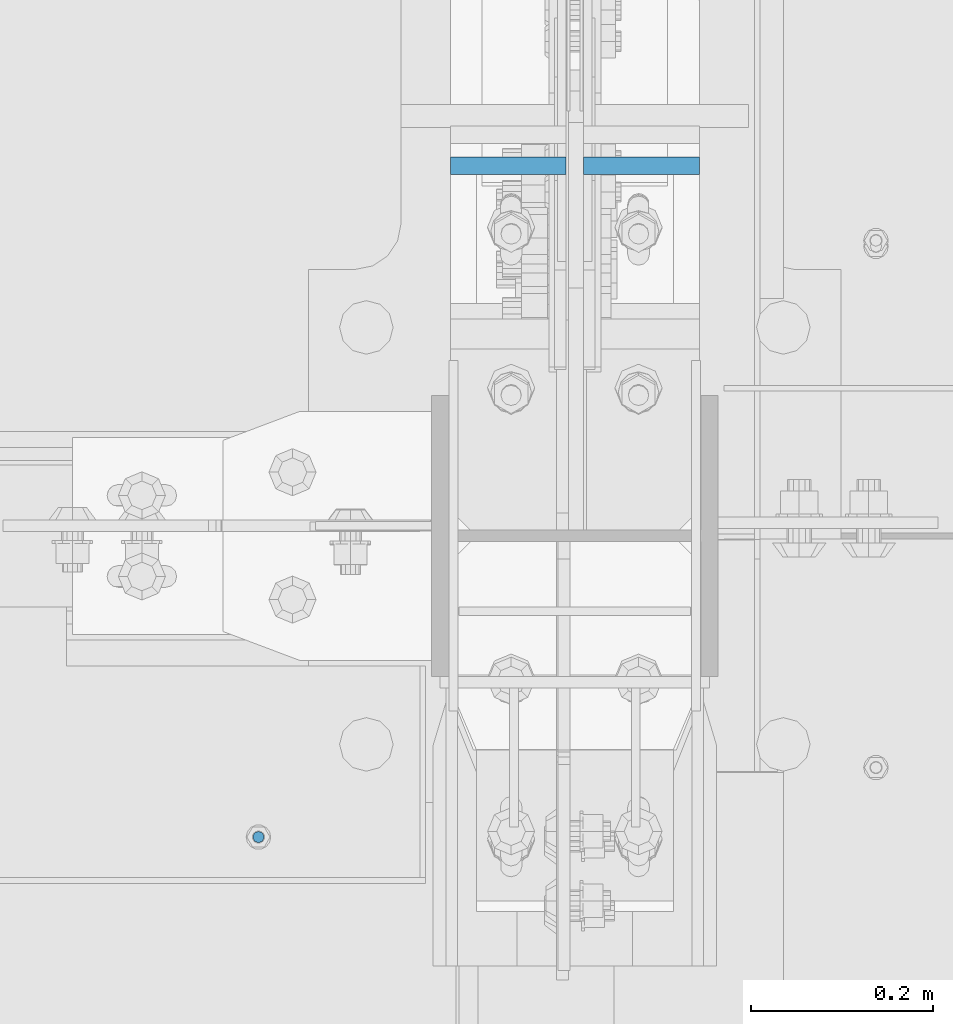
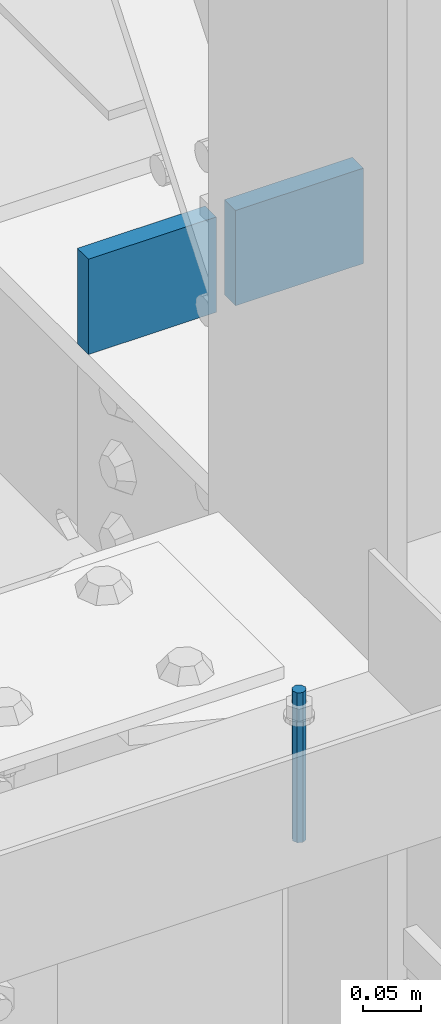
# One storey, part 467 of 1179: 3 columns, 2 elements without a shape of their own.
"""IFC2X3 building model written with IfcOpenShell, lengths in millimetres."""

from ifc_helpers import new_model, si_unit, frame, origin_with_axes, place, context, subcontext, project, spatial, faceted_brep, material, type_object, element, aggregate, save


model = new_model("IFC2X3")

# Units and contexts
model_context = context("Model", 3, precision=1e-05, world=origin_with_axes())
body_context = subcontext(model_context, "Body", "Model", "MODEL_VIEW")
ifc_project = project(units=[si_unit("LENGTHUNIT", "METRE", prefix="MILLI"), si_unit("AREAUNIT", "SQUARE_METRE"), si_unit("VOLUMEUNIT", "CUBIC_METRE"), si_unit("MASSUNIT", "GRAM", prefix="KILO"), si_unit("TIMEUNIT", "SECOND"), si_unit("PLANEANGLEUNIT", "RADIAN"), si_unit("SOLIDANGLEUNIT", "STERADIAN"), si_unit("THERMODYNAMICTEMPERATUREUNIT", "DEGREE_CELSIUS"), si_unit("LUMINOUSINTENSITYUNIT", "LUMEN")], contexts=[model_context])

# Site, building, storey
site_placement = place(None, origin_with_axes())
site = spatial("IfcSite", under=ifc_project, at=site_placement, CompositionType="ELEMENT")
building_placement = place(site_placement, origin_with_axes())
building = spatial("IfcBuilding", under=site, at=building_placement, Name="Undefined", CompositionType="ELEMENT")
storey_placement = place(building_placement, origin_with_axes())
storey = spatial("IfcBuildingStorey", under=building, at=storey_placement, Name="Undefined", CompositionType="ELEMENT", Elevation=0.0)

# Assembly, column
assembly_1_placement = place(storey_placement, origin_with_axes())
assembly_1 = element("IfcElementAssembly", 1, at=assembly_1_placement, inside=storey, Name="BEAM", AssemblyPlace="NOTDEFINED", PredefinedType="RIGID_FRAME")
ifc_material_1 = material(Name="STEEL/A307")
column_type_1 = type_object("IfcColumnType", PredefinedType="NOTDEFINED")
column_1_placement = place(assembly_1_placement, frame((23960.9315, 26720.8, 8020.05), z_axis=(0.0, 1.0, 0.0), x_axis=(0.0, 0.0, 1.0)))
column_1 = element("IfcColumn", 2, at=column_1_placement, type_object=column_type_1, material=ifc_material_1, Name="THREADED ROD", context=body_context, shape_type="Brep", body=[
    faceted_brep([(0.0, -6.34999999999854, 0.0), (0.0, -4.49012806053361, -4.49012806053452), (157.162499999999, -4.49012806053361, -4.49012806053361), (157.162499999999, -6.34999999999854, 0.0), (0.0, 0.0, -6.34999999999991), (157.162499999999, 0.0, -6.34999999999854), (0.0, 4.49012806053361, -4.49012806053452), (157.162499999999, 4.49012806053361, -4.49012806053361), (0.0, 6.34999999999854, 0.0), (157.162499999999, 6.34999999999854, 0.0), (0.0, 4.49012806053361, 4.49012806053452), (157.162499999999, 4.49012806053361, 4.49012806053361), (0.0, 0.0, 6.34999999999991), (157.162499999999, 0.0, 6.34999999999854), (0.0, -4.49012806053361, 4.49012806053452), (157.162499999999, -4.49012806053361, 4.49012806053361)], [[[0, 1, 2, 3]], [[1, 4, 5, 2]], [[4, 6, 7, 5]], [[6, 8, 9, 7]], [[8, 10, 11, 9]], [[10, 12, 13, 11]], [[12, 14, 15, 13]], [[14, 0, 3, 15]], [[5, 7, 9, 11, 13, 15, 3, 2]], [[14, 12, 10, 8, 6, 4, 1, 0]]]),
])
aggregate(assembly_1, [column_1])

# Assembly, columns
assembly_2_placement = place(storey_placement, origin_with_axes())
assembly_2 = element("IfcElementAssembly", 3, at=assembly_2_placement, inside=storey, Name="COLUMN", AssemblyPlace="NOTDEFINED", PredefinedType="RIGID_FRAME")
ifc_material_2 = material(Name="STEEL/A572-GR.50")
column_type_2 = type_object("IfcColumnType", PredefinedType="NOTDEFINED")
column_2_placement = place(assembly_2_placement, frame((24234.775, 27456.7838209118, 8013.7), z_axis=(-1.0, 0.0, 0.0), x_axis=(0.0, 0.0, 1.0)))
column_2 = element("IfcColumn", 4, at=column_2_placement, type_object=column_type_2, material=ifc_material_2, Name="PLATE", context=body_context, shape_type="Brep", body=[
    faceted_brep([(0.0, 9.52500000000146, -63.5), (0.0, 9.52500000000146, 63.5), (100.0125, 9.52500000000146, 63.5), (100.0125, 9.52500000000146, -63.5), (0.0, -9.52500000000146, 63.5), (100.0125, -9.52500000000146, 63.5), (0.0, -9.52500000000146, -63.5), (100.0125, -9.52500000000146, -63.5)], [[[0, 1, 2, 3]], [[1, 4, 5, 2]], [[4, 6, 7, 5]], [[6, 0, 3, 7]], [[5, 7, 3, 2]], [[6, 4, 1, 0]]]),
])
column_3_placement = place(assembly_2_placement, frame((24380.825, 27456.7838209118, 8013.7), z_axis=(-1.0, 0.0, 0.0), x_axis=(0.0, 0.0, 1.0)))
column_3 = element("IfcColumn", 5, at=column_3_placement, type_object=column_type_2, material=ifc_material_2, Name="PLATE", context=body_context, shape_type="Brep", body=[
    faceted_brep([(0.0, 9.52500000000146, -63.5), (0.0, 9.52500000000146, 63.5), (100.0125, 9.52500000000146, 63.5), (100.0125, 9.52500000000146, -63.5), (0.0, -9.52500000000146, 63.5), (100.0125, -9.52500000000146, 63.5), (0.0, -9.52500000000146, -63.5), (100.0125, -9.52500000000146, -63.5)], [[[0, 1, 2, 3]], [[1, 4, 5, 2]], [[4, 6, 7, 5]], [[6, 0, 3, 7]], [[5, 7, 3, 2]], [[6, 4, 1, 0]]]),
])
aggregate(assembly_2, [column_2, column_3])

save(model, "model.ifc")
